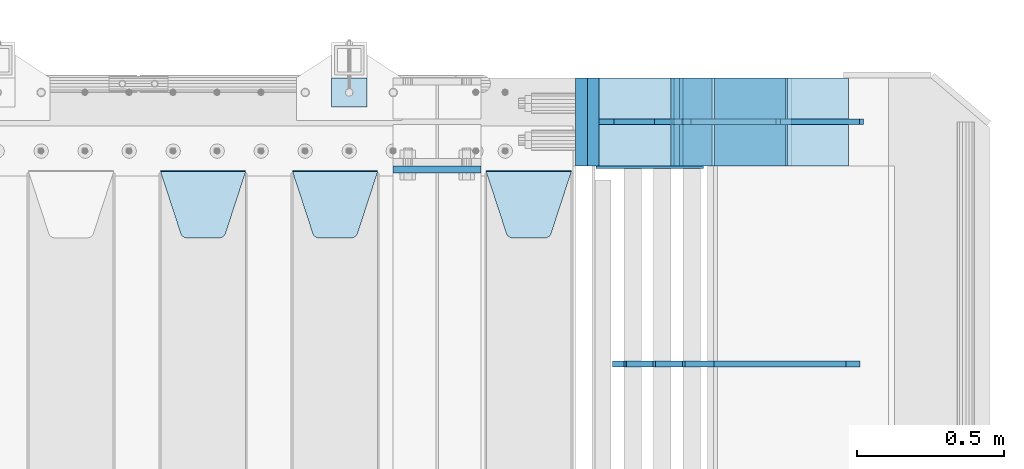
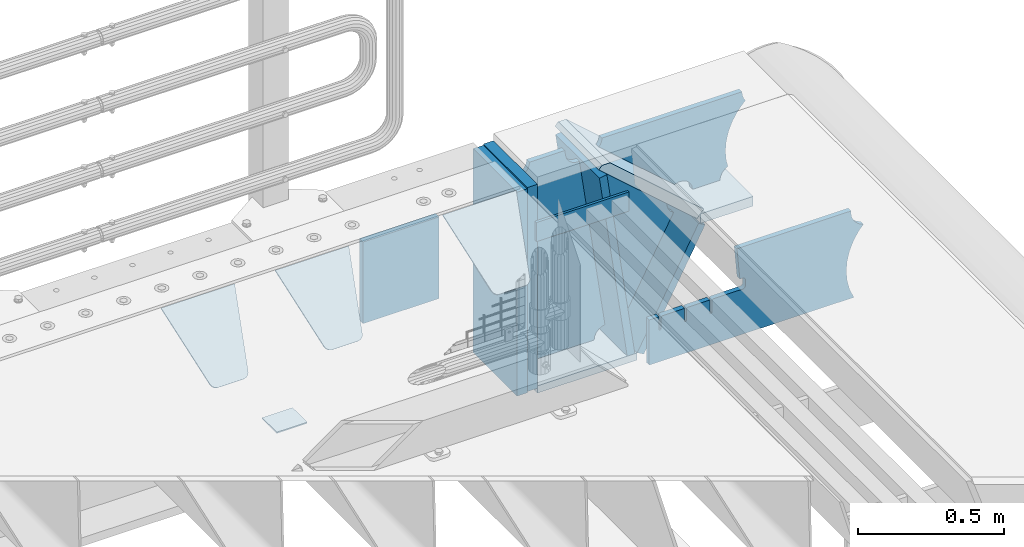
# One storey, part 252 of 270: 17 plates.
"""IFC2X3 building model written with IfcOpenShell, lengths in millimetres."""

from ifc_helpers import new_model, si_unit, frame, origin_with_axes, place, context, subcontext, project, spatial, faceted_brep, material, type_object, element, save


model = new_model("IFC2X3")

# Units and contexts
model_context = context("Model", 3, precision=1e-05, world=origin_with_axes())
body_context = subcontext(model_context, "Body", "Model", "MODEL_VIEW")
ifc_project = project(units=[si_unit("LENGTHUNIT", "METRE", prefix="MILLI"), si_unit("AREAUNIT", "SQUARE_METRE"), si_unit("VOLUMEUNIT", "CUBIC_METRE"), si_unit("MASSUNIT", "GRAM", prefix="KILO"), si_unit("TIMEUNIT", "SECOND"), si_unit("PLANEANGLEUNIT", "RADIAN"), si_unit("SOLIDANGLEUNIT", "STERADIAN"), si_unit("THERMODYNAMICTEMPERATUREUNIT", "DEGREE_CELSIUS"), si_unit("LUMINOUSINTENSITYUNIT", "LUMEN")], contexts=[model_context])

# Site, building, storey
site_placement = place(None, origin_with_axes())
site = spatial("IfcSite", under=ifc_project, at=site_placement, CompositionType="ELEMENT")
building_placement = place(site_placement, origin_with_axes())
building = spatial("IfcBuilding", under=site, at=building_placement, Name="Standard", CompositionType="ELEMENT")
storey_placement = place(building_placement, origin_with_axes())
storey = spatial("IfcBuildingStorey", under=building, at=storey_placement, Name="Undefined", CompositionType="ELEMENT", Elevation=0.0)

# Plates
ifc_material_1 = material(Name="STEEL/S355N")
plate_type_1 = type_object("IfcPlateType", PredefinedType="NOTDEFINED")
plate_1_placement = place(storey_placement, frame((19768.0, -15162.5, -340.000000000044), z_axis=(0.0, 0.0, 1.0), x_axis=(1.0, 0.0, 0.0)))
element("IfcPlate", 1, at=plate_1_placement, inside=storey, type_object=plate_type_1, material=ifc_material_1, context=body_context, shape_type="Brep", body=[
    faceted_brep([(0.0, -12.5, 0.0), (9.27684595808387e-10, -12.5, 340.0), (9.27684595808387e-10, 12.5, 340.0), (0.0, 12.5, 0.0), (300.0, -12.5, 340.0), (300.0, 12.5, 340.0), (300.0, -12.5, 0.0), (300.0, 12.5, 0.0)], [[[0, 1, 2, 3]], [[1, 4, 5, 2]], [[4, 6, 7, 5]], [[6, 0, 3, 7]], [[5, 7, 3, 2]], [[6, 4, 1, 0]]]),
])
ifc_material_2 = material(Name="STEEL/S355J2")
plate_type_2 = type_object("IfcPlateType", PredefinedType="NOTDEFINED")
plate_2_placement = place(storey_placement, frame((19558.0000000001, -14949.9999999998, -857.500000000002), z_axis=(0.0, 1.0, 0.0), x_axis=(1.0, 0.0, 0.0)))
element("IfcPlate", 2, at=plate_2_placement, inside=storey, type_object=plate_type_2, material=ifc_material_2, context=body_context, shape_type="Brep", body=[
    faceted_brep([(0.0, -2.5, 0.0), (0.0, -2.5, 100.0), (0.0, 2.5, 100.0), (0.0, 2.5, 0.0), (120.0, -2.5, 100.0), (120.0, 2.5, 100.0), (120.0, -2.5, 0.0), (120.0, 2.5, 0.0)], [[[0, 1, 2, 3]], [[1, 4, 5, 2]], [[4, 6, 7, 5]], [[6, 0, 3, 7]], [[5, 7, 3, 2]], [[6, 4, 1, 0]]]),
])
plate_type_3 = type_object("IfcPlateType", PredefinedType="NOTDEFINED")
plate_3_placement = place(storey_placement, frame((20085.0, -15168.2322330441, -1.76776695296576), z_axis=(0.0, -0.707106781186548, -0.707106781186547), x_axis=(1.0, 0.0, 0.0)))
element("IfcPlate", 3, at=plate_3_placement, inside=storey, type_object=plate_type_3, material=ifc_material_1, context=body_context, shape_type="Brep", body=[
    faceted_brep([(0.0, -2.5, 0.0), (69.345504679477, -2.5, 300.171731424831), (69.345504679477, 2.5, 300.171731424831), (0.0, 2.5, 0.0), (70.9274061199576, -2.5, 304.8974424154), (70.9274061199576, 2.5, 304.8974424154), (73.3818627772307, -2.49999999999818, 309.234538108527), (73.3818627772307, 2.50000000000182, 309.234538108527), (76.6187032999551, -2.5, 313.023683126103), (76.6187032999551, 2.5, 313.023683126103), (80.5190132704993, -2.5, 316.125672595372), (80.5190132704993, 2.50000000000182, 316.125672595372), (84.9395038596849, -2.49999999999818, 318.426546230476), (84.9395038596849, 2.5, 318.426546230476), (89.7177759439219, -2.49999999999818, 319.841774983275), (89.7177759439219, 2.50000000000182, 319.841774983275), (94.678286292652, -2.5, 320.319366455078), (94.678286292652, 2.5, 320.319366455078), (195.321713707348, -2.5, 320.319366455078), (195.321713707348, 2.5, 320.319366455078), (200.282224056078, -2.49999999999818, 319.841774983275), (200.282224056078, 2.50000000000182, 319.841774983275), (205.060496140315, -2.5, 318.426546230476), (205.060496140315, 2.5, 318.426546230476), (209.480986729501, -2.5, 316.12567259537), (209.480986729501, 2.50000000000182, 316.12567259537), (213.381296700045, -2.5, 313.023683126103), (213.381296700045, 2.5, 313.023683126103), (216.618137222769, -2.49999999999818, 309.234538108525), (216.618137222769, 2.50000000000182, 309.234538108527), (219.072593880042, -2.49999999999818, 304.897442415398), (219.072593880042, 2.50000000000182, 304.897442415397), (220.654495320523, -2.5, 300.171731424831), (220.654495320523, 2.5, 300.171731424831), (290.0, -2.49999999999818, 0.0), (290.0, 2.5, 0.0)], [[[0, 1, 2, 3]], [[1, 4, 5, 2]], [[4, 6, 7, 5]], [[6, 8, 9, 7]], [[8, 10, 11, 9]], [[10, 12, 13, 11]], [[12, 14, 15, 13]], [[14, 16, 17, 15]], [[16, 18, 19, 17]], [[18, 20, 21, 19]], [[20, 22, 23, 21]], [[22, 24, 25, 23]], [[24, 26, 27, 25]], [[26, 28, 29, 27]], [[28, 30, 31, 29]], [[30, 32, 33, 31]], [[32, 34, 35, 33]], [[34, 0, 3, 35]], [[5, 7, 9, 11, 13, 15, 17, 19, 21, 23, 25, 27, 29, 31, 33, 35, 3, 2]], [[34, 32, 30, 28, 26, 24, 22, 20, 18, 16, 14, 12, 10, 8, 6, 4, 1, 0]]]),
])
plate_4_placement = place(storey_placement, frame((19425.0, -15168.2322330441, -1.76776695296576), z_axis=(0.0, -0.707106781186548, -0.707106781186547), x_axis=(1.0, 0.0, 0.0)))
element("IfcPlate", 4, at=plate_4_placement, inside=storey, type_object=plate_type_3, material=ifc_material_1, context=body_context, shape_type="Brep", body=[
    faceted_brep([(0.0, -2.5, 0.0), (69.345504679477, -2.5, 300.171731424831), (69.345504679477, 2.5, 300.171731424831), (0.0, 2.5, 0.0), (70.9274061199576, -2.5, 304.8974424154), (70.9274061199576, 2.5, 304.8974424154), (73.3818627772307, -2.49999999999818, 309.234538108527), (73.3818627772307, 2.50000000000182, 309.234538108527), (76.6187032999551, -2.5, 313.023683126103), (76.6187032999551, 2.5, 313.023683126103), (80.5190132704993, -2.5, 316.125672595372), (80.5190132704993, 2.50000000000182, 316.125672595372), (84.9395038596849, -2.49999999999818, 318.426546230476), (84.9395038596849, 2.5, 318.426546230476), (89.7177759439219, -2.49999999999818, 319.841774983275), (89.7177759439219, 2.50000000000182, 319.841774983275), (94.678286292652, -2.5, 320.319366455078), (94.678286292652, 2.5, 320.319366455078), (195.321713707348, -2.5, 320.319366455078), (195.321713707348, 2.5, 320.319366455078), (200.282224056078, -2.49999999999818, 319.841774983275), (200.282224056078, 2.50000000000182, 319.841774983275), (205.060496140315, -2.5, 318.426546230476), (205.060496140315, 2.5, 318.426546230476), (209.480986729501, -2.5, 316.12567259537), (209.480986729501, 2.50000000000182, 316.12567259537), (213.381296700045, -2.5, 313.023683126103), (213.381296700045, 2.5, 313.023683126103), (216.618137222769, -2.49999999999818, 309.234538108525), (216.618137222769, 2.50000000000182, 309.234538108527), (219.072593880042, -2.49999999999818, 304.897442415398), (219.072593880042, 2.50000000000182, 304.897442415397), (220.654495320523, -2.5, 300.171731424831), (220.654495320523, 2.5, 300.171731424831), (290.0, -2.49999999999818, 0.0), (290.0, 2.5, 0.0)], [[[0, 1, 2, 3]], [[1, 4, 5, 2]], [[4, 6, 7, 5]], [[6, 8, 9, 7]], [[8, 10, 11, 9]], [[10, 12, 13, 11]], [[12, 14, 15, 13]], [[14, 16, 17, 15]], [[16, 18, 19, 17]], [[18, 20, 21, 19]], [[20, 22, 23, 21]], [[22, 24, 25, 23]], [[24, 26, 27, 25]], [[26, 28, 29, 27]], [[28, 30, 31, 29]], [[30, 32, 33, 31]], [[32, 34, 35, 33]], [[34, 0, 3, 35]], [[5, 7, 9, 11, 13, 15, 17, 19, 21, 23, 25, 27, 29, 31, 33, 35, 3, 2]], [[34, 32, 30, 28, 26, 24, 22, 20, 18, 16, 14, 12, 10, 8, 6, 4, 1, 0]]]),
])
plate_5_placement = place(storey_placement, frame((18975.0, -15168.2322330441, -1.76776695296576), z_axis=(0.0, -0.707106781186548, -0.707106781186547), x_axis=(1.0, 0.0, 0.0)))
element("IfcPlate", 5, at=plate_5_placement, inside=storey, type_object=plate_type_3, material=ifc_material_1, context=body_context, shape_type="Brep", body=[
    faceted_brep([(0.0, -2.5, 0.0), (69.345504679477, -2.5, 300.171731424831), (69.345504679477, 2.5, 300.171731424831), (0.0, 2.5, 0.0), (70.9274061199576, -2.5, 304.8974424154), (70.9274061199576, 2.5, 304.8974424154), (73.3818627772307, -2.49999999999818, 309.234538108527), (73.3818627772307, 2.50000000000182, 309.234538108527), (76.6187032999551, -2.5, 313.023683126103), (76.6187032999551, 2.5, 313.023683126103), (80.5190132704993, -2.5, 316.125672595372), (80.5190132704993, 2.50000000000182, 316.125672595372), (84.9395038596849, -2.49999999999818, 318.426546230476), (84.9395038596849, 2.5, 318.426546230476), (89.7177759439219, -2.49999999999818, 319.841774983275), (89.7177759439219, 2.50000000000182, 319.841774983275), (94.678286292652, -2.5, 320.319366455078), (94.678286292652, 2.5, 320.319366455078), (195.321713707348, -2.5, 320.319366455078), (195.321713707348, 2.5, 320.319366455078), (200.282224056078, -2.49999999999818, 319.841774983275), (200.282224056078, 2.50000000000182, 319.841774983275), (205.060496140315, -2.5, 318.426546230476), (205.060496140315, 2.5, 318.426546230476), (209.480986729501, -2.5, 316.12567259537), (209.480986729501, 2.50000000000182, 316.12567259537), (213.381296700045, -2.5, 313.023683126103), (213.381296700045, 2.5, 313.023683126103), (216.618137222769, -2.49999999999818, 309.234538108525), (216.618137222769, 2.50000000000182, 309.234538108527), (219.072593880042, -2.49999999999818, 304.897442415398), (219.072593880042, 2.50000000000182, 304.897442415397), (220.654495320523, -2.5, 300.171731424831), (220.654495320523, 2.5, 300.171731424831), (290.0, -2.49999999999818, 0.0), (290.0, 2.5, 0.0)], [[[0, 1, 2, 3]], [[1, 4, 5, 2]], [[4, 6, 7, 5]], [[6, 8, 9, 7]], [[8, 10, 11, 9]], [[10, 12, 13, 11]], [[12, 14, 15, 13]], [[14, 16, 17, 15]], [[16, 18, 19, 17]], [[18, 20, 21, 19]], [[20, 22, 23, 21]], [[22, 24, 25, 23]], [[24, 26, 27, 25]], [[26, 28, 29, 27]], [[28, 30, 31, 29]], [[30, 32, 33, 31]], [[32, 34, 35, 33]], [[34, 0, 3, 35]], [[5, 7, 9, 11, 13, 15, 17, 19, 21, 23, 25, 27, 29, 31, 33, 35, 3, 2]], [[34, 32, 30, 28, 26, 24, 22, 20, 18, 16, 14, 12, 10, 8, 6, 4, 1, 0]]]),
])
ifc_material_3 = material()
plate_type_4 = type_object("IfcPlateType", PredefinedType="NOTDEFINED")
plate_6_placement = place(storey_placement, frame((20410.0, -14850.0, -875.0), z_axis=(0.0, 0.0, 1.0), x_axis=(0.0, -1.0, 0.0)))
element("IfcPlate", 6, at=plate_6_placement, inside=storey, type_object=plate_type_4, material=ifc_material_3, context=body_context, shape_type="Brep", body=[
    faceted_brep([(0.0, -20.0, 0.0), (0.0, -20.0, 850.0), (0.0, 20.0, 850.0), (0.0, 20.0, 0.0), (300.0, -20.0, 850.0), (300.0, 20.0, 850.0), (300.0, -20.0, -1.81898940354586e-12), (300.0, 20.0, -1.81898940354586e-12)], [[[0, 1, 2, 3]], [[1, 4, 5, 2]], [[4, 6, 7, 5]], [[6, 0, 3, 7]], [[5, 7, 3, 2]], [[6, 4, 1, 0]]]),
])
plate_7_placement = place(storey_placement, frame((21111.9988298898, -14850.0000000008, -367.999999999302), z_axis=(-0.752989422949573, 0.0, 0.658032619955933), x_axis=(0.0, -1.0, 0.0)))
element("IfcPlate", 7, at=plate_7_placement, inside=storey, type_object=plate_type_4, material=ifc_material_1, context=body_context, shape_type="Brep", body=[
    faceted_brep([(-8.11269273981452e-10, 19.9999999999982, 490.766265601622), (0.0, -0.303811250943909, 514.0), (300.0, -0.303811250943909, 514.0), (300.0, 19.9999999999982, 490.766265601622), (300.0, -20.0, -1.81898940354586e-12), (300.0, -20.0000000000018, 514.000000000002), (0.0, -20.0000000000018, 514.000000000002), (0.0, -20.0, 0.0), (0.0, 20.0, 0.0), (300.0, 20.0, -1.81898940354586e-12)], [[[0, 1, 2, 3]], [[4, 5, 6, 7]], [[4, 7, 8, 9]], [[9, 8, 0, 3]], [[5, 4, 9, 3, 2]], [[6, 5, 2, 1]], [[8, 7, 6, 1, 0]]]),
])
plate_8_placement = place(storey_placement, frame((20449.9988298906, -14850.0, -870.000000000003), z_axis=(0.0, 0.0, 1.0), x_axis=(0.0, -1.0, 0.0)))
element("IfcPlate", 8, at=plate_8_placement, inside=storey, type_object=plate_type_4, material=ifc_material_3, context=body_context, shape_type="Brep", body=[
    faceted_brep([(0.0, -20.0, 0.0), (0.0, -20.0, 850.0), (0.0, 20.0, 850.0), (0.0, 20.0, 0.0), (300.0, -20.0, 850.0), (300.0, 20.0, 850.0), (300.0, -20.0, -1.81898940354586e-12), (300.0, 20.0, -1.81898940354586e-12)], [[[0, 1, 2, 3]], [[1, 4, 5, 2]], [[4, 6, 7, 5]], [[6, 0, 3, 7]], [[5, 7, 3, 2]], [[6, 4, 1, 0]]]),
])
plate_type_5 = type_object("IfcPlateType", PredefinedType="NOTDEFINED")
plate_9_placement = place(storey_placement, frame((21111.9988298898, -15150.0000000008, -387.999999999302), z_axis=(1.0, 0.0, 0.0), x_axis=(0.0, 1.0, 0.0)))
element("IfcPlate", 9, at=plate_9_placement, inside=storey, type_object=plate_type_5, material=ifc_material_1, context=body_context, shape_type="Brep", body=[
    faceted_brep([(0.0, -20.0, 0.0), (3.31056071445346e-10, -20.0, 208.0), (3.31056071445346e-10, 20.0, 208.0), (0.0, 20.0, 0.0), (300.0, -20.0, 208.0), (300.0, 20.0, 208.0), (300.0, -20.0, -1.81898940354586e-12), (300.0, 20.0, -1.81898940354586e-12)], [[[0, 1, 2, 3]], [[1, 4, 5, 2]], [[4, 6, 7, 5]], [[6, 0, 3, 7]], [[5, 7, 3, 2]], [[6, 4, 1, 0]]]),
])
plate_type_6 = type_object("IfcPlateType", PredefinedType="NOTDEFINED")
plate_10_placement = place(storey_placement, frame((20708.998829889, -15000.0, -30.0000000032531), z_axis=(0.0, 0.0, -1.0), x_axis=(-1.0, 0.0, 0.0)))
element("IfcPlate", 10, at=plate_10_placement, inside=storey, type_object=plate_type_6, material=ifc_material_1, context=body_context, shape_type="Brep", body=[
    faceted_brep([(-9.00602409638668, -10.0, 65.0), (-108.137843376921, -10.0, 780.473130459514), (-108.137843376921, 10.0, 780.473130459514), (-9.00602409638668, 10.0, 65.0), (-94.4157884488377, -10.0, 784.433672138112), (-94.4157884488377, 10.0, 784.433672138112), (-82.3732461236723, -10.0, 792.112074067144), (-82.3732461236723, 10.0, 792.112074067144), (-72.9927947992364, -10.0, 802.881837982249), (-72.9927947992364, 10.0, 802.881837982249), (-67.0398068183713, -10.0, 815.864234368775), (-67.0398068183713, 10.0, 815.864234368775), (-65.0, -10.0, 830.0), (-65.0, 10.0, 830.0), (189.0, -10.0, 830.0), (189.0, 10.0, 830.0), (191.447174185243, -10.0, 814.549150281253), (191.447174185243, 10.0, 814.549150281253), (198.549150281251, -10.0, 800.610737385376), (198.549150281251, 10.0, 800.610737385376), (209.610737385377, -10.0, 789.549150281253), (209.610737385377, 10.0, 789.549150281253), (223.549150281251, -10.0, 782.447174185242), (223.549150281251, 10.0, 782.447174185242), (239.0, -10.0, 780.0), (239.0, 10.0, 780.0), (239.0, -10.0, 50.0), (239.0, 10.0, 50.0), (223.549150281251, -10.0, 47.5528258147577), (223.549150281251, 10.0, 47.5528258147577), (209.610737385377, -10.0, 40.4508497187474), (209.610737385377, 10.0, 40.4508497187474), (198.549150281251, -10.0, 29.3892626146237), (198.549150281251, 10.0, 29.3892626146237), (191.447174185243, -10.0, 15.4508497187474), (191.447174185243, 10.0, 15.4508497187474), (189.0, -10.0, 0.0), (189.0, 10.0, 0.0), (50.4776502774184, -10.0, 0.0), (50.4776502774184, 10.0, 0.0), (47.3830020671812, -10.0, 22.3352870825933), (47.3830020671812, 10.0, 22.3352870825933), (42.8384615202776, -10.0, 37.3040735979326), (42.8384615202776, 10.0, 37.3040735979326), (33.8907372011709, -10.0, 50.1358952937587), (33.8907372011709, 10.0, 50.1358952937587), (21.4156947086703, -10.0, 59.5746840579253), (21.4156947086703, 10.0, 59.5746840579253), (6.63447812067898, -10.0, 64.6965054822873), (6.63447812067898, 10.0, 64.6965054822873)], [[[0, 1, 2, 3]], [[1, 4, 5, 2]], [[4, 6, 7, 5]], [[6, 8, 9, 7]], [[8, 10, 11, 9]], [[10, 12, 13, 11]], [[12, 14, 15, 13]], [[14, 16, 17, 15]], [[16, 18, 19, 17]], [[18, 20, 21, 19]], [[20, 22, 23, 21]], [[22, 24, 25, 23]], [[24, 26, 27, 25]], [[26, 28, 29, 27]], [[28, 30, 31, 29]], [[30, 32, 33, 31]], [[32, 34, 35, 33]], [[34, 36, 37, 35]], [[36, 38, 39, 37]], [[38, 40, 41, 39]], [[40, 42, 43, 41]], [[42, 44, 45, 43]], [[44, 46, 47, 45]], [[46, 48, 49, 47]], [[48, 0, 3, 49]], [[5, 7, 9, 11, 13, 15, 17, 19, 21, 23, 25, 27, 29, 31, 33, 35, 37, 39, 41, 43, 45, 47, 49, 3, 2]], [[48, 46, 44, 42, 40, 38, 36, 34, 32, 30, 28, 26, 24, 22, 20, 18, 16, 14, 12, 10, 8, 6, 4, 1, 0]]]),
])
plate_type_7 = type_object("IfcPlateType", PredefinedType="NOTDEFINED")
plate_11_placement = place(storey_placement, frame((21426.9988298898, -15000.0000000006, -29.9999999993023), z_axis=(-0.000446694000102124, 0.0, -0.99999990023223), x_axis=(-0.99999990023223, 0.0, 0.000446694000103734)))
element("IfcPlate", 11, at=plate_11_placement, inside=storey, type_object=plate_type_7, material=ifc_material_1, context=body_context, shape_type="Brep", body=[
    faceted_brep([(125.007775472979, 10.0, 291.842314882029), (131.755016800053, 10.0, 263.793234614468), (131.755016800053, -10.0, 263.793234614468), (125.007775472979, -10.0, 291.842314882029), (134.899927074483, 10.0, 224.060281342732), (134.899927074483, -10.0, 224.060281342732), (131.79051499522, 10.0, 184.324534302446), (131.79051499522, -10.0, 184.324534302446), (122.503344607208, 10.0, 145.564419461128), (122.503344607208, -10.0, 145.564419461128), (107.267096867745, 10.0, 108.734339483616), (107.267096867745, -10.0, 108.734339483616), (86.4569387623887, 10.0, 74.741173170983), (86.4569387623887, -10.0, 74.741173170983), (60.5852854486511, 10.0, 44.4219450946983), (60.5852854486511, -10.0, 44.4219450946983), (56.2519855253086, 10.0, 40.7176084148888), (56.2519855253086, -10.0, 40.7176084148888), (136.409234539125, -10.0, 297.721677540594), (147.386991180581, -10.0, 308.778803581017), (147.386991180581, 10.0, 308.778803581017), (136.409234539125, 10.0, 297.721677540594), (154.428166132755, -10.0, 322.678193223937), (154.428166132755, 10.0, 322.678193223937), (156.849001662977, -10.0, 338.070097995228), (156.849001662977, 10.0, 338.070097995228), (264.849004013293, -10.0, 338.118348049693), (264.849004013293, 10.0, 338.118348049693), (267.62876711955, -10.0, 321.701412969031), (267.62876711955, 10.0, 321.701412969031), (275.645118712178, -10.0, 307.107546191754), (275.645118712178, 10.0, 307.107546191754), (288.009068357209, -10.0, 295.955165748785), (288.009068357209, 10.0, 295.955165748785), (303.34948944753, -10.0, 289.481038692482), (303.34948944753, 10.0, 289.481038692482), (319.965173216926, -10.0, 288.403127172445), (319.965173216926, 10.0, 288.403127172445), (336.013487920231, -10.0, 292.840968489265), (336.013487920231, 10.0, 292.840968489265), (335.869079589844, -10.0, 293.150054931641), (335.869079589844, 10.0, 293.150054931641), (633.937057436444, -10.0, 32.8861672876965), (633.937057436444, 10.0, 32.8861672876965), (628.672097726401, -10.0, 25.6357574923157), (628.672097726401, 10.0, 25.6357574923157), (624.785781531271, -10.0, 17.5620477266101), (624.785781531271, 10.0, 17.5620477266101), (622.402919050601, -10.0, 8.92432757904926), (622.402919050601, 10.0, 8.92432757904926), (621.600036621097, -10.0, -8.74678107720683e-10), (621.600036621097, 10.0, -8.74678107720683e-10), (70.0, -10.0, -9.85025394584227e-11), (70.0, 10.0, -9.85025394584227e-11), (67.7728137216618, -10.0, 17.5170123094482), (67.7728137216618, 10.0, 17.5170123094482), (61.2329794213983, -10.0, 33.9193489203215), (61.2329794213983, 10.0, 33.9193489203215)], [[[0, 1, 2, 3]], [[4, 5, 2, 1]], [[6, 7, 5, 4]], [[8, 9, 7, 6]], [[10, 11, 9, 8]], [[12, 13, 11, 10]], [[14, 15, 13, 12]], [[16, 17, 15, 14]], [[18, 19, 20, 21]], [[19, 22, 23, 20]], [[22, 24, 25, 23]], [[24, 26, 27, 25]], [[26, 28, 29, 27]], [[28, 30, 31, 29]], [[30, 32, 33, 31]], [[32, 34, 35, 33]], [[34, 36, 37, 35]], [[36, 38, 39, 37]], [[38, 40, 41, 39]], [[40, 42, 43, 41]], [[42, 44, 45, 43]], [[44, 46, 47, 45]], [[46, 48, 49, 47]], [[48, 50, 51, 49]], [[50, 52, 53, 51]], [[52, 54, 55, 53]], [[54, 56, 57, 55]], [[12, 10, 8, 6, 4, 1, 0, 21, 20, 23, 25, 27, 29, 31, 33, 35, 37, 39, 41, 43, 45, 47, 49, 51, 53, 55, 57, 16, 14]], [[18, 21, 0, 3]], [[56, 54, 52, 50, 48, 46, 44, 42, 40, 38, 36, 34, 32, 30, 28, 26, 24, 22, 19, 18, 3, 2, 5, 7, 9, 11, 13, 15, 17]], [[57, 56, 17, 16]]]),
])
plate_type_8 = type_object("IfcPlateType", PredefinedType="NOTDEFINED")
plate_12_placement = place(storey_placement, frame((21111.0025685034, -14999.999999999, -393.996688204407), z_axis=(-0.658066357015091, 0.0, -0.752959939017267), x_axis=(-0.752959939017266, 0.0, 0.658066357015093)))
element("IfcPlate", 12, at=plate_12_placement, inside=storey, type_object=plate_type_8, material=ifc_material_1, context=body_context, shape_type="Brep", body=[
    faceted_brep([(-11.3595226159596, -10.0, 48.6925173505915), (-112.015767301031, -10.0, 480.154833723633), (-112.015767301031, 10.0, 480.154833723633), (-11.3595226159596, 10.0, 48.6925173505915), (-104.567323293641, -10.0, 482.519601382543), (-104.567323293641, 10.0, 482.519601382543), (-97.5783311599989, -10.0, 486.016090073756), (-97.5783311599989, 10.0, 486.016090073756), (-91.2195220373833, -10.0, 490.558885551656), (-91.2195220373833, 10.0, 490.558885551656), (-85.6462325884258, -10.0, 496.037013784004), (-85.6462325884258, 10.0, 496.037013784004), (447.024482710494, -10.0, 32.8103372896385), (447.024482710494, 10.0, 32.8103372896385), (441.786973010396, -10.0, 25.570962393731), (441.786973010396, 10.0, 25.570962393731), (437.921644570126, -10.0, 17.5149526624118), (437.921644570126, 10.0, 17.5149526624118), (435.551940606494, -10.0, 8.89958500531975), (435.551940606494, 10.0, 8.89958500531975), (434.753540039061, -10.0, -5.16592990607023e-10), (434.753540039061, 10.0, -5.16592990607023e-10), (50.0, -10.0, 0.0), (50.0, 10.0, 0.0), (47.7668538974231, -10.0, 14.7759151575174), (47.7668538974231, 10.0, 14.7759151575174), (41.2668932502802, -10.0, 28.2319592212443), (41.2668932502802, 10.0, 28.2319592212443), (31.0807325300157, -10.0, 39.1661596968297), (31.0807325300157, 10.0, 39.1661596968297), (18.1182591411489, -10.0, 46.6018098971963), (18.1182591411489, 10.0, 46.6018098971963), (3.53735696080548, -10.0, 49.874714091733), (3.53735696080548, 10.0, 49.874714091733)], [[[0, 1, 2, 3]], [[1, 4, 5, 2]], [[4, 6, 7, 5]], [[6, 8, 9, 7]], [[8, 10, 11, 9]], [[10, 12, 13, 11]], [[12, 14, 15, 13]], [[14, 16, 17, 15]], [[16, 18, 19, 17]], [[18, 20, 21, 19]], [[20, 22, 23, 21]], [[22, 24, 25, 23]], [[24, 26, 27, 25]], [[26, 28, 29, 27]], [[28, 30, 31, 29]], [[30, 32, 33, 31]], [[32, 0, 3, 33]], [[5, 7, 9, 11, 13, 15, 17, 19, 21, 23, 25, 27, 29, 31, 33, 3, 2]], [[32, 30, 28, 26, 24, 22, 20, 18, 16, 14, 12, 10, 8, 6, 4, 1, 0]]]),
])
plate_type_9 = type_object("IfcPlateType", PredefinedType="NOTDEFINED")
plate_13_placement = place(storey_placement, frame((20862.9988298891, -14850.0, -875.000000003253), z_axis=(0.0, -1.0, 0.0), x_axis=(-1.0, 0.0, 0.0)))
element("IfcPlate", 13, at=plate_13_placement, inside=storey, type_object=plate_type_9, material=ifc_material_1, context=body_context, shape_type="Brep", body=[
    faceted_brep([(0.0, -15.0, 0.0), (0.0, -15.0, 300.0), (0.0, 15.0, 300.0), (0.0, 15.0, 0.0), (393.0, -15.0, 300.0), (393.0, 15.0, 300.0), (393.0, -15.0, 0.0), (393.0, 15.0, 0.0)], [[[0, 1, 2, 3]], [[1, 4, 5, 2]], [[4, 6, 7, 5]], [[6, 0, 3, 7]], [[5, 7, 3, 2]], [[6, 4, 1, 0]]]),
])
plate_14_placement = place(storey_placement, frame((20839.1480677219, -14849.999999999, -862.083788721732), z_axis=(-0.139173011053008, 0.0, 0.990268081377179), x_axis=(0.0, -1.0, 0.0)))
element("IfcPlate", 14, at=plate_14_placement, inside=storey, type_object=plate_type_9, material=ifc_material_1, context=body_context, shape_type="Brep", body=[
    faceted_brep([(1.00408215075731e-09, 14.9994702460499, -0.00376939767329532), (300.0, 15.0, 0.0), (300.0, -15.0000000000036, 4.21237841386937), (0.0, -15.0000000000036, 4.21237841386937), (0.0, -15.0, 792.0), (300.0, -15.0, 792.0), (300.0, 14.9999999999964, 792.0), (0.0, 14.9999999999964, 792.0)], [[[0, 1, 2, 3]], [[4, 5, 6, 7]], [[4, 7, 0, 3]], [[5, 4, 3, 2]], [[6, 5, 2, 1]], [[7, 6, 1, 0]]]),
])
plate_15_placement = place(storey_placement, frame((20876.2468009566, -14849.999999999, -867.038754739308), z_axis=(0.469471552246176, 0.0, 0.882947598462992), x_axis=(0.0, -1.0, 0.0)))
element("IfcPlate", 15, at=plate_15_placement, inside=storey, type_object=plate_type_9, material=ifc_material_1, context=body_context, shape_type="Brep", body=[
    faceted_brep([(0.0, -15.0, 0.0), (0.0, -15.0, 515.000000000002), (0.0, 15.0000000000036, 515.000000000004), (0.0, 15.0, 0.0), (300.0, -15.0, 515.000000000002), (300.0, 15.0000000000036, 515.000000000004), (300.0, -15.0, 0.0), (300.0, 15.0, 0.0)], [[[0, 1, 2, 3]], [[1, 4, 5, 2]], [[4, 6, 7, 5]], [[6, 0, 3, 7]], [[5, 7, 3, 2]], [[6, 4, 1, 0]]]),
])
plate_type_10 = type_object("IfcPlateType", PredefinedType="NOTDEFINED")
plate_16_placement = place(storey_placement, frame((21355.9182339676, -15825.0007171631, -374.002067436516), z_axis=(0.0, 0.0, 1.0), x_axis=(-1.0, 0.0, 0.0)))
element("IfcPlate", 16, at=plate_16_placement, inside=storey, type_object=plate_type_10, material=ifc_material_1, context=body_context, shape_type="Brep", body=[
    faceted_brep([(801.919404066546, -10.0, 188.0), (801.919404066546, 10.0, 188.0), (801.919404066546, 10.0, 132.002067436952), (801.919404066546, -10.0, 132.002067436952), (793.919404066546, 10.0, 132.002067436952), (793.919404066546, -10.0, 132.002067436952), (793.919404066546, 10.0, 180.002067436952), (793.919404066546, -10.0, 180.002067436952), (793.527856196906, 10.0, 182.474203391951), (793.527856196906, -10.0, 182.474203391951), (792.391540021545, 10.0, 184.704349455291), (792.391540021545, -10.0, 184.704349455291), (790.621686084887, 10.0, 186.474203391951), (790.621686084887, -10.0, 186.474203391951), (788.391540021545, 10.0, 187.610519567313), (788.391540021545, -10.0, 187.610519567313), (785.919404066546, -10.0, 188.002067436952), (785.919404066546, 10.0, 188.0), (841.0, -10.0, 188.0), (841.0, -10.0, 0.0), (841.0, 10.0, 0.0), (841.0, 10.0, 188.0), (33.3619566735979, -10.0, 0.0), (33.3619566735979, 10.0, 0.0), (36.2350612208174, -10.0, 4.68848050267013), (36.2350612208174, 10.0, 4.68848050267013), (51.4877592159428, -10.0, 41.5117508652784), (51.4877592159428, 10.0, 41.5117508652784), (60.792242588137, -10.0, 80.2677133162964), (60.792242588137, 10.0, 80.2677133162964), (63.9194040769726, -10.0, 120.002067436515), (63.9194040769726, 10.0, 120.002067436515), (60.792242588137, -10.0, 159.736421556734), (60.792242588137, 10.0, 159.736421556734), (51.4877592159428, -10.0, 198.492384007752), (51.4877592159428, 10.0, 198.492384007752), (36.2350612208174, -10.0, 235.31565437036), (36.2350612208174, 10.0, 235.31565437036), (15.4097206482074, -10.0, 269.299521518803), (15.4097206482074, 10.0, 269.299521518803), (-3.35474438098754, -10.0, 291.269887256574), (-3.35474438098754, 10.0, 291.269887256574), (-2.36881039375294, -10.0, 291.426043859339), (-2.36881039375294, 10.0, 291.426043859339), (17.1449676604716, -10.0, 301.368810393754), (17.1449676604716, 10.0, 301.368810393754), (32.6311896062471, -10.0, 316.855032339527), (32.6311896062471, 10.0, 316.855032339527), (42.573956140659, -10.0, 336.368810393754), (42.573956140659, 10.0, 336.368810393754), (46.0, -10.0, 358.0), (46.0, 10.0, 358.0), (45.0495205499174, -10.0, 364.001091067617), (45.0495205499174, 10.0, 364.001091067617), (495.040008544922, -10.0, 364.010009765625), (495.040008544922, 10.0, 364.010009765625), (483.600036621094, -10.0, 233.759994506836), (483.600036621094, 10.0, 233.759994506836), (472.0, -10.0, 233.759994506836), (472.0, 10.0, 233.759994506836), (468.909830056251, -10.0, 233.270559669787), (468.909830056251, 10.0, 233.270559669787), (466.122147477075, -10.0, 231.850164450585), (466.122147477075, 10.0, 231.850164450585), (463.909830056251, -10.0, 229.637847029761), (463.909830056251, 10.0, 229.637847029761), (462.489434837047, -10.0, 226.850164450585), (462.489434837047, 10.0, 226.850164450585), (462.0, -10.0, 223.759994506836), (462.0, 10.0, 223.759994506836), (462.0, -10.0, 198.0), (462.0, 10.0, 198.0), (462.489434837047, -10.0, 194.909830056251), (462.489434837047, 10.0, 194.909830056251), (463.909830056251, -10.0, 192.122147477075), (463.909830056251, 10.0, 192.122147477075), (466.122147477075, -10.0, 189.909830056251), (466.122147477075, 10.0, 189.909830056251), (468.909830056251, -10.0, 188.489434837048), (468.909830056251, 10.0, 188.489434837048), (472.0, -10.0, 188.0), (472.0, 10.0, 188.0), (585.919404066546, -10.0, 188.002067436952), (585.919404066546, 10.0, 188.0), (588.391540021545, -10.0, 187.610519567313), (588.391540021545, 10.0, 187.610519567313), (590.621686084887, -10.0, 186.474203391951), (590.621686084887, 10.0, 186.474203391951), (592.391540021545, -10.0, 184.704349455291), (592.391540021545, 10.0, 184.704349455291), (593.527856196906, -10.0, 182.474203391951), (593.527856196906, 10.0, 182.474203391951), (593.919404066546, -10.0, 180.002067436952), (593.919404066546, 10.0, 180.002067436952), (593.919404066546, -10.0000000000036, 132.002067436952), (593.919404066546, 10.0, 132.002067436952), (601.919404066546, -10.0000000000036, 132.002067436952), (601.919404066546, 10.0, 132.002067436952), (601.919404066546, -10.0, 188.0), (601.919404066546, 10.0, 188.0), (685.919404066546, -10.0, 188.002067436952), (685.919404066546, 10.0, 188.0), (688.391540021545, -10.0, 187.610519567313), (688.391540021545, 10.0, 187.610519567313), (690.621686084887, -10.0, 186.474203391951), (690.621686084887, 10.0, 186.474203391951), (692.391540021545, -10.0, 184.704349455291), (692.391540021545, 10.0, 184.704349455291), (693.527856196906, -10.0, 182.474203391951), (693.527856196906, 10.0, 182.474203391951), (693.919404066546, -10.0, 180.002067436952), (693.919404066546, 10.0, 180.002067436952), (693.919404066546, -10.0, 132.002067436952), (693.919404066546, 10.0, 132.002067436952), (701.919404066546, -10.0, 132.002067436952), (701.919404066546, 10.0, 132.002067436952), (701.919404066546, -10.0, 188.0), (701.919404066546, 10.0, 188.0)], [[[0, 1, 2, 3]], [[3, 2, 4, 5]], [[5, 4, 6, 7]], [[7, 6, 8, 9]], [[9, 8, 10, 11]], [[11, 10, 12, 13]], [[13, 12, 14, 15]], [[16, 15, 14, 17]], [[18, 19, 20, 21]], [[20, 19, 22, 23]], [[22, 24, 25, 23]], [[26, 27, 25, 24]], [[28, 29, 27, 26]], [[30, 31, 29, 28]], [[32, 33, 31, 30]], [[34, 35, 33, 32]], [[36, 37, 35, 34]], [[38, 39, 37, 36]], [[39, 38, 40, 41]], [[40, 42, 43, 41]], [[44, 45, 43, 42]], [[46, 47, 45, 44]], [[48, 49, 47, 46]], [[50, 51, 49, 48]], [[52, 53, 51, 50]], [[54, 55, 53, 52]], [[54, 56, 57, 55]], [[56, 58, 59, 57]], [[58, 60, 61, 59]], [[60, 62, 63, 61]], [[62, 64, 65, 63]], [[64, 66, 67, 65]], [[66, 68, 69, 67]], [[68, 70, 71, 69]], [[70, 72, 73, 71]], [[72, 74, 75, 73]], [[74, 76, 77, 75]], [[76, 78, 79, 77]], [[78, 80, 81, 79]], [[81, 80, 82, 83]], [[82, 84, 85, 83]], [[86, 87, 85, 84]], [[88, 89, 87, 86]], [[90, 91, 89, 88]], [[92, 93, 91, 90]], [[94, 95, 93, 92]], [[96, 97, 95, 94]], [[98, 99, 97, 96]], [[99, 98, 100, 101]], [[100, 102, 103, 101]], [[104, 105, 103, 102]], [[106, 107, 105, 104]], [[108, 109, 107, 106]], [[110, 111, 109, 108]], [[112, 113, 111, 110]], [[114, 115, 113, 112]], [[116, 117, 115, 114]], [[117, 116, 16, 17]], [[12, 10, 8, 6, 4, 2, 1, 21, 20, 23, 25, 27, 29, 31, 33, 35, 37, 39, 41, 43, 45, 47, 49, 51, 53, 55, 57, 59, 61, 63, 65, 67, 69, 71, 73, 75, 77, 79, 81, 83, 85, 87, 89, 91, 93, 95, 97, 99, 101, 103, 105, 107, 109, 111, 113, 115, 117, 17, 14]], [[18, 21, 1, 0]], [[116, 114, 112, 110, 108, 106, 104, 102, 100, 98, 96, 94, 92, 90, 88, 86, 84, 82, 80, 78, 76, 74, 72, 70, 68, 66, 64, 62, 60, 58, 56, 54, 52, 50, 48, 46, 44, 42, 40, 38, 36, 34, 32, 30, 28, 26, 24, 22, 19, 18, 0, 3, 5, 7, 9, 11, 13, 15, 16]]]),
])
plate_type_11 = type_object("IfcPlateType", PredefinedType="NOTDEFINED")
plate_17_placement = place(storey_placement, frame((20824.998829901, -15155.0000995771, -249.999999999564), z_axis=(-1.0, 0.0, 0.0), x_axis=(0.0, 0.0, 1.0)))
element("IfcPlate", 17, at=plate_17_placement, inside=storey, type_object=plate_type_11, material=ifc_material_1, context=body_context, shape_type="Brep", body=[
    faceted_brep([(0.0, -5.0, 0.0), (0.0, -5.0, 365.0), (0.0, 5.0, 365.0), (0.0, 5.0, 0.0), (80.0, -5.0, 365.0), (80.0, 5.0, 365.0), (80.0, -5.0, 0.0), (80.0, 5.0, 0.0)], [[[0, 1, 2, 3]], [[1, 4, 5, 2]], [[4, 6, 7, 5]], [[6, 0, 3, 7]], [[5, 7, 3, 2]], [[6, 4, 1, 0]]]),
])

save(model, "model.ifc")
